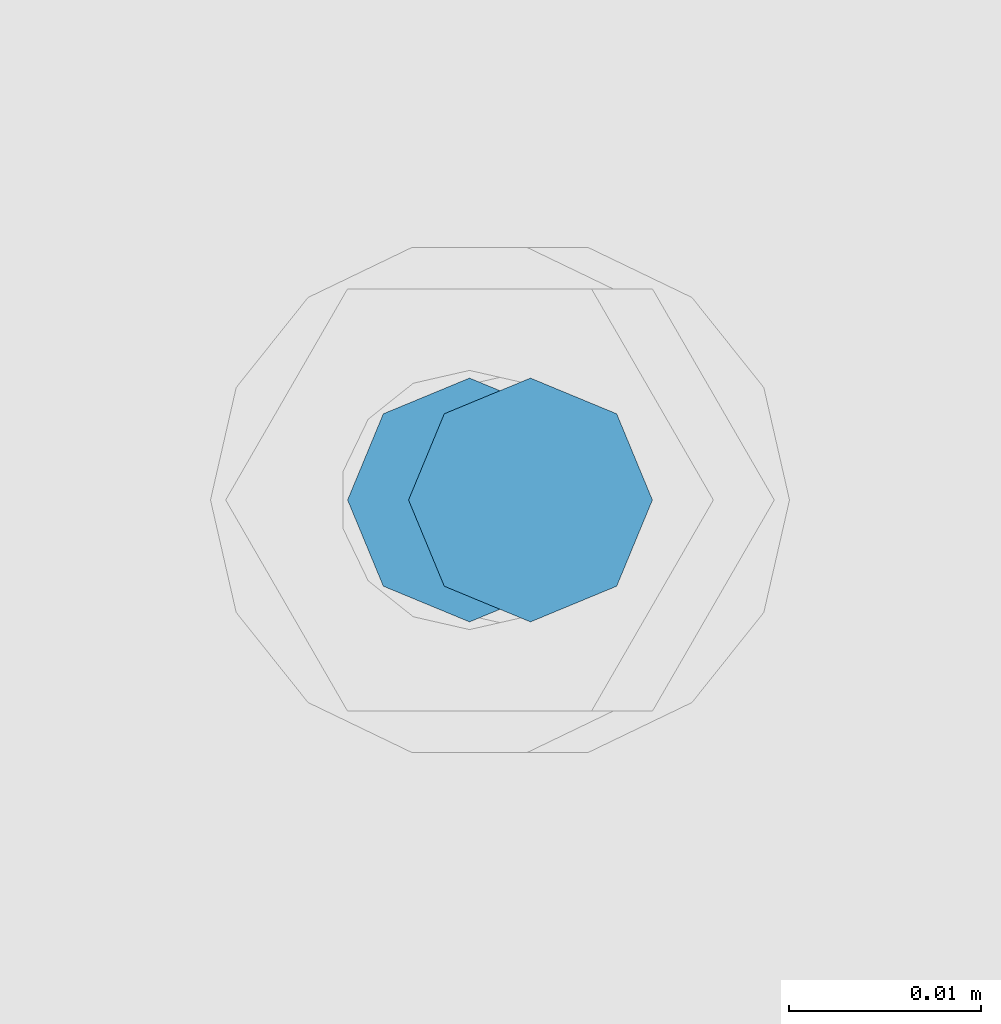
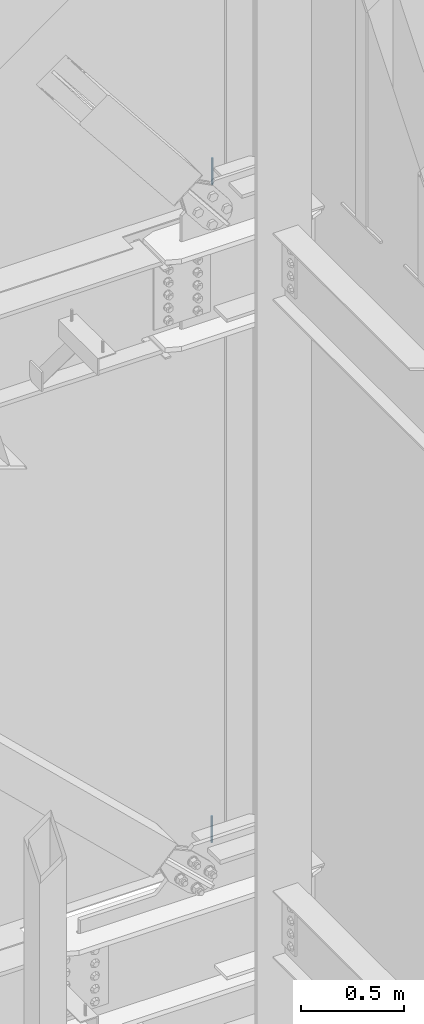
# One storey, part 589 of 1179: 2 columns, 2 elements without a shape of their own.
"""IFC2X3 building model written with IfcOpenShell, lengths in millimetres."""

from ifc_helpers import new_model, si_unit, frame, origin_with_axes, place, context, subcontext, project, spatial, faceted_brep, material, type_object, element, aggregate, save


model = new_model("IFC2X3")

# Units and contexts
model_context = context("Model", 3, precision=1e-05, world=origin_with_axes())
body_context = subcontext(model_context, "Body", "Model", "MODEL_VIEW")
ifc_project = project(units=[si_unit("LENGTHUNIT", "METRE", prefix="MILLI"), si_unit("AREAUNIT", "SQUARE_METRE"), si_unit("VOLUMEUNIT", "CUBIC_METRE"), si_unit("MASSUNIT", "GRAM", prefix="KILO"), si_unit("TIMEUNIT", "SECOND"), si_unit("PLANEANGLEUNIT", "RADIAN"), si_unit("SOLIDANGLEUNIT", "STERADIAN"), si_unit("THERMODYNAMICTEMPERATUREUNIT", "DEGREE_CELSIUS"), si_unit("LUMINOUSINTENSITYUNIT", "LUMEN")], contexts=[model_context])

# Site, building, storey
site_placement = place(None, origin_with_axes())
site = spatial("IfcSite", under=ifc_project, at=site_placement, CompositionType="ELEMENT")
building_placement = place(site_placement, origin_with_axes())
building = spatial("IfcBuilding", under=site, at=building_placement, Name="Undefined", CompositionType="ELEMENT")
storey_placement = place(building_placement, origin_with_axes())
storey = spatial("IfcBuildingStorey", under=building, at=storey_placement, Name="Undefined", CompositionType="ELEMENT", Elevation=0.0)

# Assembly, column
assembly_1_placement = place(storey_placement, origin_with_axes())
assembly_1 = element("IfcElementAssembly", 1, at=assembly_1_placement, inside=storey, Name="BEAM", AssemblyPlace="NOTDEFINED", PredefinedType="RIGID_FRAME")
ifc_material = material(Name="STEEL/A307")
column_type = type_object("IfcColumnType", PredefinedType="NOTDEFINED")
column_1_placement = place(assembly_1_placement, frame((16335.375, 41529.0, 8020.05), z_axis=(0.0, 1.0, 0.0), x_axis=(0.0, 0.0, 1.0)))
column_1 = element("IfcColumn", 2, at=column_1_placement, type_object=column_type, material=ifc_material, Name="THREADED ROD", context=body_context, shape_type="Brep", body=[
    faceted_brep([(0.0, -6.34999999999854, 0.0), (0.0, -4.49012806053361, -4.49012806053452), (157.162499999999, -4.49012806053361, -4.49012806053361), (157.162499999999, -6.34999999999854, 0.0), (0.0, 0.0, -6.34999999999991), (157.162499999999, 0.0, -6.34999999999854), (0.0, 4.49012806053361, -4.49012806053452), (157.162499999999, 4.49012806053361, -4.49012806053361), (0.0, 6.34999999999854, 0.0), (157.162499999999, 6.34999999999854, 0.0), (0.0, 4.49012806053361, 4.49012806053452), (157.162499999999, 4.49012806053361, 4.49012806053361), (0.0, 0.0, 6.34999999999991), (157.162499999999, 0.0, 6.34999999999854), (0.0, -4.49012806053361, 4.49012806053452), (157.162499999999, -4.49012806053361, 4.49012806053361)], [[[0, 1, 2, 3]], [[1, 4, 5, 2]], [[4, 6, 7, 5]], [[6, 8, 9, 7]], [[8, 10, 11, 9]], [[10, 12, 13, 11]], [[12, 14, 15, 13]], [[14, 0, 3, 15]], [[5, 7, 9, 11, 13, 15, 3, 2]], [[14, 12, 10, 8, 6, 4, 1, 0]]]),
])
aggregate(assembly_1, [column_1])

assembly_2_placement = place(storey_placement, origin_with_axes())
assembly_2 = element("IfcElementAssembly", 3, at=assembly_2_placement, inside=storey, Name="BEAM", AssemblyPlace="NOTDEFINED", PredefinedType="RIGID_FRAME")
column_2_placement = place(assembly_2_placement, frame((16332.1999938965, 41529.0, 4108.45), z_axis=(0.0, 1.0, 0.0), x_axis=(0.0, 0.0, 1.0)))
column_2 = element("IfcColumn", 4, at=column_2_placement, type_object=column_type, material=ifc_material, Name="THREADED ROD", context=body_context, shape_type="Brep", body=[
    faceted_brep([(0.0, -6.34999999999854, 0.0), (0.0, -4.49012806053361, -4.49012806053452), (157.162499999999, -4.49012806053361, -4.49012806053361), (157.162499999999, -6.34999999999854, 0.0), (0.0, 0.0, -6.34999999999991), (157.162499999999, 0.0, -6.34999999999854), (0.0, 4.49012806053361, -4.49012806053452), (157.162499999999, 4.49012806053361, -4.49012806053361), (0.0, 6.34999999999854, 0.0), (157.162499999999, 6.34999999999854, 0.0), (0.0, 4.49012806053361, 4.49012806053452), (157.162499999999, 4.49012806053361, 4.49012806053361), (0.0, 0.0, 6.34999999999991), (157.162499999999, 0.0, 6.34999999999854), (0.0, -4.49012806053361, 4.49012806053452), (157.162499999999, -4.49012806053361, 4.49012806053361)], [[[0, 1, 2, 3]], [[1, 4, 5, 2]], [[4, 6, 7, 5]], [[6, 8, 9, 7]], [[8, 10, 11, 9]], [[10, 12, 13, 11]], [[12, 14, 15, 13]], [[14, 0, 3, 15]], [[5, 7, 9, 11, 13, 15, 3, 2]], [[14, 12, 10, 8, 6, 4, 1, 0]]]),
])
aggregate(assembly_2, [column_2])

save(model, "model.ifc")
